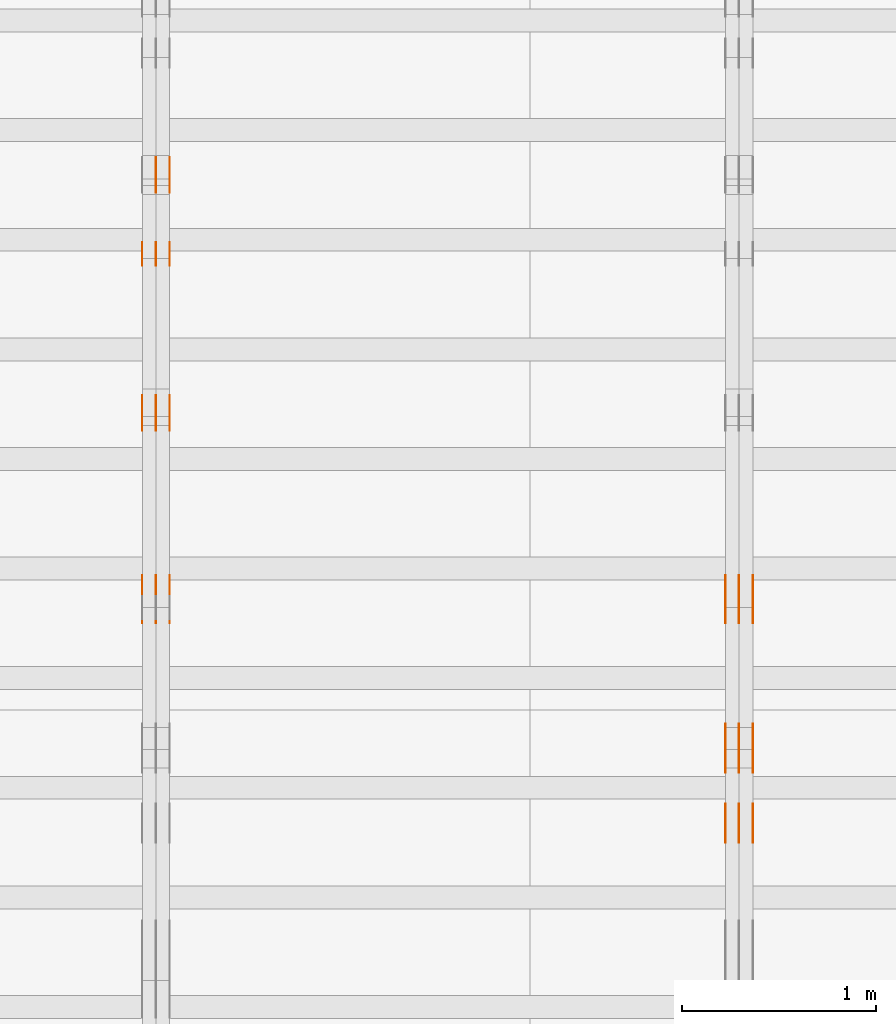
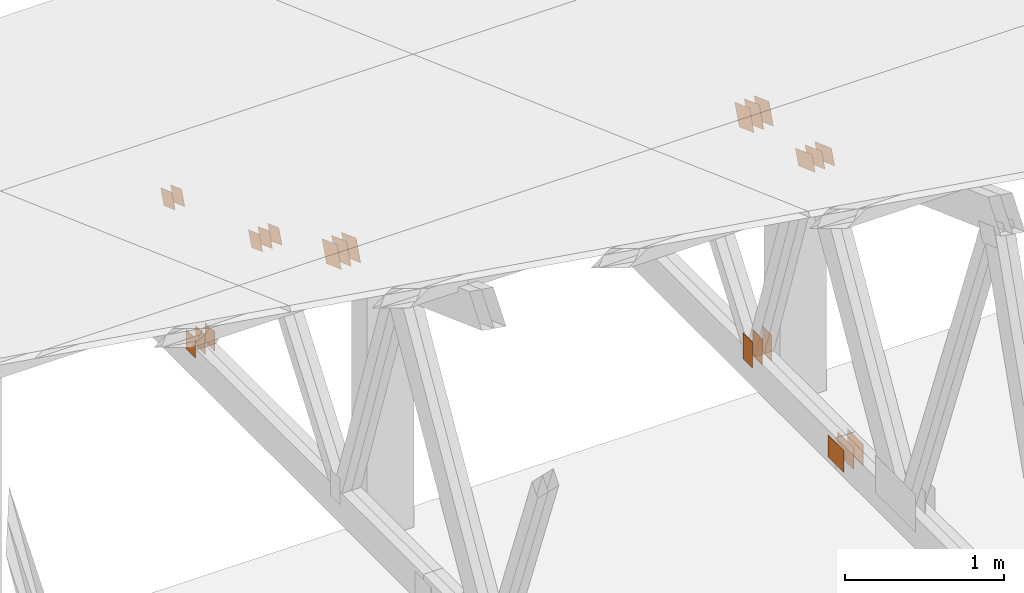
# One storey, part 132 of 189: 31 proxies.
"""IFC2X3 building model written with IfcOpenShell, lengths in millimetres."""

import ifcopenshell
import ifcopenshell.guid

model = None  # the IFC model being written
_history = None  # IfcOwnerHistory: only IFC2X3 demands one
_inside = {}  # id of a spatial element -> (the spatial element, [elements in it])
_under = {}  # id of a project, library or spatial element -> (it, [spatial elements below it])
_declared = {}  # id of a project -> (the project, [libraries it declares])
_typed = {}  # id of a type object -> (the type object, [elements of that type])
_made_of = {}  # id of a material, layer set ... -> (it, [elements and type objects made of it])


def new_model(schema):
    """Start an empty IFC model of exactly this schema.

    Asked for "IFC4X3", IfcOpenShell would pick the latest addendum, in which some entities
    have other attributes; the version numbers below select the first issue.
    IFC2X3 requires an IfcOwnerHistory on every rooted entity: one is made here for all.
    """
    global model, _history
    if schema == "IFC4X3":
        model = ifcopenshell.file(schema_version=(4, 3, 0, 0))
    else:
        model = ifcopenshell.file(schema=schema)
    _inside.clear()
    _under.clear()
    _declared.clear()
    _typed.clear()
    _made_of.clear()
    _history = None
    if model.schema == "IFC2X3":
        org = make("IfcOrganization", Name="unknown")
        user = make(
            "IfcPersonAndOrganization",
            ThePerson=make("IfcPerson", FamilyName="unknown"),
            TheOrganization=org,
        )
        app = make(
            "IfcApplication",
            ApplicationDeveloper=org,
            Version="unknown",
            ApplicationFullName="unknown",
            ApplicationIdentifier="unknown",
        )
        _history = make(
            "IfcOwnerHistory",
            OwningUser=user,
            OwningApplication=app,
            ChangeAction="ADDED",
            CreationDate=0,
        )
    return model


def make(cls, **values):
    """One entity of the class cls with the attributes given. An attribute that is None is left unset."""
    return model.create_entity(
        cls, **{name: value for name, value in values.items() if value is not None}
    )


def entity(cls, *values):
    """Any entity or typed value of the class cls, its attributes in the order of the schema. None: left unset."""
    e = model.create_entity(cls)
    for i, value in enumerate(values):
        if value is not None:
            e[i] = value
    return e


def rooted(cls, **values):
    """An entity with a GlobalId (a new one), such as an element, a storey or a relation."""
    return make(cls, GlobalId=ifcopenshell.guid.new(), OwnerHistory=_history, **values)


def si_unit(unit_type, name, prefix=None):
    """IfcSIUnit, for example si_unit("LENGTHUNIT", "METRE", prefix="MILLI")."""
    return make("IfcSIUnit", UnitType=unit_type, Prefix=prefix, Name=name)


def converted_unit(unit_type, name, factor, base, dimensions=None, offset=None):
    """IfcConversionBasedUnit, such as the inch: factor (a typed value) times the base unit."""
    return make(
        "IfcConversionBasedUnit"
        if offset is None
        else "IfcConversionBasedUnitWithOffset",
        ConversionOffset=offset,
        Dimensions=None
        if dimensions is None
        else entity("IfcDimensionalExponents", *dimensions),
        UnitType=unit_type,
        Name=name,
        ConversionFactor=make(
            "IfcMeasureWithUnit", ValueComponent=factor, UnitComponent=base
        ),
    )


def derived_unit(unit_type, elements):
    """IfcDerivedUnit: a product of units, each with its exponent."""
    return make(
        "IfcDerivedUnit",
        Elements=[
            make("IfcDerivedUnitElement", Unit=unit, Exponent=power)
            for unit, power in elements
        ],
        UnitType=unit_type,
    )


def assignment(units):
    """IfcUnitAssignment: the units of a project."""
    return None if units is None else make("IfcUnitAssignment", Units=units)


def point(xyz):
    """IfcCartesianPoint."""
    return None if xyz is None else make("IfcCartesianPoint", Coordinates=xyz)


def direction(xyz):
    """IfcDirection."""
    return None if xyz is None else make("IfcDirection", DirectionRatios=xyz)


def frame(location, z_axis=None, x_axis=None):
    """IfcAxis2Placement3D, a coordinate frame: its origin and axes. An axis left out is left unset."""
    return make(
        "IfcAxis2Placement3D",
        Location=point(location),
        Axis=direction(z_axis),
        RefDirection=direction(x_axis),
    )


def frame_2d(location, x_axis=None):
    """IfcAxis2Placement2D, a coordinate frame in the plane: its origin and x axis."""
    return make(
        "IfcAxis2Placement2D", Location=point(location), RefDirection=direction(x_axis)
    )


def origin():
    """The frame at (0, 0, 0) with its axes left unset."""
    return frame((0.0, 0.0, 0.0))


def origin_2d_with_axis():
    """The frame at (0, 0) in the plane with the x axis (1, 0) written out."""
    return frame_2d((0.0, 0.0), x_axis=(1.0, 0.0))


def place(relative_to, where):
    """IfcLocalPlacement: puts the frame where relative to a parent placement (None: the world)."""
    return make(
        "IfcLocalPlacement", PlacementRelTo=relative_to, RelativePlacement=where
    )


def context(
    kind, dimensions, precision=None, world=None, true_north=None, identifier=None
):
    """IfcGeometricRepresentationContext, for example the 3D "Model" context."""
    return make(
        "IfcGeometricRepresentationContext",
        ContextIdentifier=identifier,
        ContextType=kind,
        CoordinateSpaceDimension=dimensions,
        Precision=precision,
        WorldCoordinateSystem=world,
        TrueNorth=true_north,
    )


def subcontext(parent, identifier, kind, view, scale=None):
    """IfcGeometricRepresentationSubContext, for example "Body" below "Model"."""
    return make(
        "IfcGeometricRepresentationSubContext",
        ContextIdentifier=identifier,
        ContextType=kind,
        ParentContext=parent,
        TargetScale=scale,
        TargetView=view,
    )


def project(units=None, contexts=None):
    """IfcProject with its units and contexts."""
    return rooted(
        "IfcProject",
        Name="project",
        RepresentationContexts=contexts,
        UnitsInContext=assignment(units),
    )


def spatial(cls, under=None, at=None, **own):
    """A site, building, storey or space (cls), placed at a placement, below another one or the project."""
    s = rooted(cls, ObjectPlacement=at, **own)
    if under is not None:
        _under.setdefault(under.id(), (under, []))[1].append(s)
    return s


def polyline(points):
    """IfcPolyline through the points."""
    return make("IfcPolyline", Points=[point(p) for p in points])


def profile(cls, at=None, kind="AREA", **sizes):
    """A parametric profile (cls). Its sizes go by their IFC names, for example OverallWidth=200.0."""
    return make(cls, ProfileType=kind, Position=at, **sizes)


def rectangle(**sizes):
    """IfcRectangleProfileDef."""
    return profile("IfcRectangleProfileDef", **sizes)


def outline(outer, holes=None, kind="AREA"):
    """IfcArbitraryClosedProfileDef: a profile drawn as a closed curve; with holes, ...WithVoids."""
    if holes is None:
        return make("IfcArbitraryClosedProfileDef", ProfileType=kind, OuterCurve=outer)
    return make(
        "IfcArbitraryProfileDefWithVoids",
        ProfileType=kind,
        OuterCurve=outer,
        InnerCurves=holes,
    )


def extrude(swept, where, along, depth):
    """IfcExtrudedAreaSolid: the profile swept, set in the frame where, extruded along a direction by depth."""
    return make(
        "IfcExtrudedAreaSolid",
        SweptArea=swept,
        Position=where,
        ExtrudedDirection=direction(along),
        Depth=depth,
    )


def shape(context_of_items, identifier, shape_type, items):
    """IfcShapeRepresentation: the items that make up one representation, for example the "Body"."""
    return make(
        "IfcShapeRepresentation",
        ContextOfItems=context_of_items,
        RepresentationIdentifier=identifier,
        RepresentationType=shape_type,
        Items=items,
    )


def source(mapping_origin, context_of_items, identifier, shape_type, items):
    """IfcRepresentationMap: a shape defined once, which mapped items show again and again."""
    return make(
        "IfcRepresentationMap",
        MappingOrigin=mapping_origin,
        MappedRepresentation=shape(context_of_items, identifier, shape_type, items),
    )


def transform(
    local_origin,
    x_axis=None,
    y_axis=None,
    z_axis=None,
    scale=None,
    scale2=None,
    scale3=None,
    uniform=True,
):
    """IfcCartesianTransformationOperator3D, or its non-uniform kind. x_axis, y_axis, z_axis: its Axis1, 2, 3."""
    if uniform:
        return make(
            "IfcCartesianTransformationOperator3D",
            Axis1=direction(x_axis),
            Axis2=direction(y_axis),
            LocalOrigin=point(local_origin),
            Scale=scale,
            Axis3=direction(z_axis),
        )
    return make(
        "IfcCartesianTransformationOperator3DnonUniform",
        Axis1=direction(x_axis),
        Axis2=direction(y_axis),
        LocalOrigin=point(local_origin),
        Scale=scale,
        Axis3=direction(z_axis),
        Scale2=scale2,
        Scale3=scale3,
    )


def mapped(mapping_source, mapping_target):
    """IfcMappedItem: shows the shape of a source again, moved by a transform."""
    return make(
        "IfcMappedItem", MappingSource=mapping_source, MappingTarget=mapping_target
    )


def material(Name=None, Category=None):
    """IfcMaterial."""
    return make("IfcMaterial", Name=Name, Category=Category)


def made_of(thing, what):
    """Note that an element or type object is made of a material, layer set ...; save() writes the relation."""
    if what is not None:
        _made_of.setdefault(what.id(), (what, []))[1].append(thing)
    return thing


def type_object(cls, material=None, **own):
    """A type object (cls), such as IfcWallType, which elements share."""
    return made_of(rooted(cls, **own), material)


def type_shapes(of_type, sources):
    """Give a type object the sources (RepresentationMaps) that its elements show as mapped items."""
    of_type.RepresentationMaps = sources


def element(
    cls,
    number,
    at=None,
    inside=None,
    cuts=None,
    type_object=None,
    material=None,
    context=None,
    identifier="Body",
    shape_type=None,
    held_by="IfcProductDefinitionShape",
    body=None,
    shapes=None,
    **own,
):
    """One element of the class cls, such as IfcWall. Its Tag is "e" and its number.

    at: its placement. inside: the storey or other place that contains it. cuts: it is an
    opening in that element (IfcRelVoidsElement). A single representation is given by context,
    identifier, shape_type and body (its items); several are given by shapes. held_by: the class
    of the entity that holds the representations. save() writes the other relations.
    """
    e = rooted(cls, Tag="e%d" % number, ObjectPlacement=at, **own)
    if body is not None:
        shapes = [shape(context, identifier, shape_type, body)]
    if shapes is not None:
        e.Representation = make(held_by, Representations=shapes)
    if inside is not None:
        _inside.setdefault(inside.id(), (inside, []))[1].append(e)
    if cuts is not None:
        rooted(
            "IfcRelVoidsElement", RelatingBuildingElement=cuts, RelatedOpeningElement=e
        )
    if type_object is not None:
        _typed.setdefault(type_object.id(), (type_object, []))[1].append(e)
    return made_of(e, material)


def aggregate(whole, parts):
    """IfcRelAggregates: a whole, such as a stair, and the parts it consists of."""
    return rooted("IfcRelAggregates", RelatingObject=whole, RelatedObjects=parts)


def save(model, path):
    """Write the relations noted so far, then the file.

    IfcRelAggregates (storeys below a building ...), IfcRelContainedInSpatialStructure (elements
    in a storey), IfcRelDefinesByType, IfcRelAssociatesMaterial and IfcRelDeclares: one each for
    every whole, place, type object, material and project.
    """
    for whole, parts in _under.values():
        aggregate(whole, parts)
    for where, things in _inside.values():
        rooted(
            "IfcRelContainedInSpatialStructure",
            RelatedElements=things,
            RelatingStructure=where,
        )
    for kind, things in _typed.values():
        rooted("IfcRelDefinesByType", RelatedObjects=things, RelatingType=kind)
    for what, things in _made_of.values():
        rooted("IfcRelAssociatesMaterial", RelatedObjects=things, RelatingMaterial=what)
    for by, libraries in _declared.values():
        rooted("IfcRelDeclares", RelatingContext=by, RelatedDefinitions=libraries)
    model.write(path)


model = new_model("IFC2X3")

# Units and contexts
model_context = context("Model", 3, precision=0.01, world=origin(), true_north=direction((6.12303176911189e-17, 1.0)))
body_context = subcontext(model_context, "Body", "Model", "MODEL_VIEW")
ifc_project = project(units=[si_unit("LENGTHUNIT", "METRE", prefix="MILLI"), si_unit("AREAUNIT", "SQUARE_METRE"), si_unit("VOLUMEUNIT", "CUBIC_METRE"), converted_unit("PLANEANGLEUNIT", "DEGREE", entity("IfcRatioMeasure", 0.0174532925199433), si_unit("PLANEANGLEUNIT", "RADIAN"), dimensions=[0, 0, 0, 0, 0, 0, 0]), si_unit("MASSUNIT", "GRAM", prefix="KILO"), derived_unit("MASSDENSITYUNIT", [(si_unit("MASSUNIT", "GRAM", prefix="KILO"), 1), (si_unit("LENGTHUNIT", "METRE"), -3)]), si_unit("TIMEUNIT", "SECOND"), si_unit("FREQUENCYUNIT", "HERTZ"), si_unit("THERMODYNAMICTEMPERATUREUNIT", "DEGREE_CELSIUS"), derived_unit("THERMALTRANSMITTANCEUNIT", [(si_unit("MASSUNIT", "GRAM", prefix="KILO"), 1), (si_unit("THERMODYNAMICTEMPERATUREUNIT", "KELVIN"), -1), (si_unit("TIMEUNIT", "SECOND"), -3)]), derived_unit("VOLUMETRICFLOWRATEUNIT", [(si_unit("LENGTHUNIT", "METRE"), 3), (si_unit("TIMEUNIT", "SECOND"), -1)]), si_unit("ELECTRICCURRENTUNIT", "AMPERE"), si_unit("ELECTRICVOLTAGEUNIT", "VOLT"), si_unit("POWERUNIT", "WATT"), si_unit("FORCEUNIT", "NEWTON"), si_unit("ILLUMINANCEUNIT", "LUX"), si_unit("LUMINOUSFLUXUNIT", "LUMEN"), si_unit("LUMINOUSINTENSITYUNIT", "CANDELA"), derived_unit("USERDEFINED", [(si_unit("MASSUNIT", "GRAM", prefix="KILO"), -1), (si_unit("LENGTHUNIT", "METRE"), -2), (si_unit("TIMEUNIT", "SECOND"), 3), (si_unit("LUMINOUSFLUXUNIT", "LUMEN"), 1)]), derived_unit("LINEARVELOCITYUNIT", [(si_unit("LENGTHUNIT", "METRE"), 1), (si_unit("TIMEUNIT", "SECOND"), -1)]), si_unit("PRESSUREUNIT", "PASCAL"), derived_unit("USERDEFINED", [(si_unit("LENGTHUNIT", "METRE"), -2), (si_unit("MASSUNIT", "GRAM", prefix="KILO"), 1), (si_unit("TIMEUNIT", "SECOND"), -2)])], contexts=[model_context])

# Site, building, storey
site_placement = place(None, origin())
site = spatial("IfcSite", under=ifc_project, at=site_placement, CompositionType="ELEMENT")
building_placement = place(site_placement, origin())
building = spatial("IfcBuilding", under=site, at=building_placement, CompositionType="ELEMENT")
storey_placement = place(building_placement, origin())
storey = spatial("IfcBuildingStorey", under=building, at=storey_placement, Name="Default", CompositionType="ELEMENT", Elevation=0.0)

# Proxies
ifc_material_1 = material(Name="IfcSurfaceStyle #169638")
building_element_proxy_type_1 = type_object("IfcBuildingElementProxyType", PredefinedType="NOTDEFINED", material=ifc_material_1)
shared_shape_1 = source(origin(), body_context, "Body", "SweptSolid", [
    extrude(outline(polyline([(-112.499846801582, -59.999986193028), (112.499924372729, -59.999986193028), (112.499888552087, 59.999986193028), (-112.499966123235, 59.999986193028), (-112.499846801582, -59.999986193028)])), frame((112.499989807712, 60.0001003787081, 0.0), z_axis=(0.0, 0.0, 1.0), x_axis=(-1.0, 0.0, 0.0)), (0.0, 0.0, 1.0), 1.3),
])
type_shapes(building_element_proxy_type_1, [shared_shape_1])
proxy_1_placement = place(building_placement, frame((30301.3, 24040.8868138992, 2049.61031693104), z_axis=(-1.0, 0.0, 0.0), x_axis=(0.0, -0.939692620785908, 0.342020143325669)))
element("IfcBuildingElementProxy", 1, at=proxy_1_placement, inside=storey, type_object=building_element_proxy_type_1, material=ifc_material_1, context=body_context, shape_type="MappedRepresentation", body=[
    mapped(shared_shape_1, transform((0.0, 0.0, 0.0), scale=1.0)),
])
ifc_material_2 = material(Name="IfcSurfaceStyle #169581")
building_element_proxy_type_2 = type_object("IfcBuildingElementProxyType", PredefinedType="NOTDEFINED", material=ifc_material_2)
shared_shape_2 = source(origin(), body_context, "Body", "SweptSolid", [
    extrude(outline(polyline([(-112.499846801582, -59.999986193028), (112.499924372729, -59.999986193028), (112.499888552087, 59.999986193028), (-112.499966123235, 59.999986193028), (-112.499846801582, -59.999986193028)])), frame((112.499989807712, 60.0001003787081, 0.0), z_axis=(0.0, 0.0, 1.0), x_axis=(-1.0, 0.0, 0.0)), (0.0, 0.0, 1.0), 1.29999999999998),
])
type_shapes(building_element_proxy_type_2, [shared_shape_2])
proxy_2_placement = place(building_placement, frame((30230.0, 24040.8868138992, 2049.61031693104), z_axis=(-1.0, 0.0, 0.0), x_axis=(0.0, -0.939692620785908, 0.342020143325669)))
element("IfcBuildingElementProxy", 2, at=proxy_2_placement, inside=storey, type_object=building_element_proxy_type_2, material=ifc_material_2, context=body_context, shape_type="MappedRepresentation", body=[
    mapped(shared_shape_2, transform((0.0, 0.0, 0.0), scale=1.0)),
])
ifc_material_3 = material(Name="IfcSurfaceStyle #169524")
building_element_proxy_type_3 = type_object("IfcBuildingElementProxyType", PredefinedType="NOTDEFINED", material=ifc_material_3)
shared_shape_3 = source(origin(), body_context, "Body", "SweptSolid", [
    extrude(outline(polyline([(-112.499846801582, -59.999986193028), (112.499924372729, -59.999986193028), (112.499888552087, 59.999986193028), (-112.499966123235, 59.999986193028), (-112.499846801582, -59.999986193028)])), frame((112.499989807712, 60.0001003787081, 0.0), z_axis=(0.0, 0.0, 1.0), x_axis=(-1.0, 0.0, 0.0)), (0.0, 0.0, 1.0), 1.29999999999998),
])
type_shapes(building_element_proxy_type_3, [shared_shape_3])
proxy_3_placement = place(building_placement, frame((30231.3, 24040.8868138992, 2049.61031693104), z_axis=(-1.0, 0.0, 0.0), x_axis=(0.0, -0.939692620785908, 0.342020143325669)))
element("IfcBuildingElementProxy", 3, at=proxy_3_placement, inside=storey, type_object=building_element_proxy_type_3, material=ifc_material_3, context=body_context, shape_type="MappedRepresentation", body=[
    mapped(shared_shape_3, transform((0.0, 0.0, 0.0), scale=1.0)),
])
ifc_material_4 = material(Name="IfcSurfaceStyle #169467")
building_element_proxy_type_4 = type_object("IfcBuildingElementProxyType", PredefinedType="NOTDEFINED", material=ifc_material_4)
shared_shape_4 = source(origin(), body_context, "Body", "SweptSolid", [
    extrude(outline(polyline([(-112.499846801582, -59.999986193028), (112.499924372729, -59.999986193028), (112.499888552087, 59.999986193028), (-112.499966123235, 59.999986193028), (-112.499846801582, -59.999986193028)])), frame((112.499989807712, 60.0001003787081, 0.0), z_axis=(0.0, 0.0, 1.0), x_axis=(-1.0, 0.0, 0.0)), (0.0, 0.0, 1.0), 1.29999999999999),
])
type_shapes(building_element_proxy_type_4, [shared_shape_4])
proxy_4_placement = place(building_placement, frame((30160.0, 24040.8868138992, 2049.61031693104), z_axis=(-1.0, 0.0, 0.0), x_axis=(0.0, -0.939692620785908, 0.342020143325669)))
element("IfcBuildingElementProxy", 4, at=proxy_4_placement, inside=storey, type_object=building_element_proxy_type_4, material=ifc_material_4, context=body_context, shape_type="MappedRepresentation", body=[
    mapped(shared_shape_4, transform((0.0, 0.0, 0.0), scale=1.0)),
])
ifc_material_5 = material(Name="IfcSurfaceStyle #169410")
building_element_proxy_type_5 = type_object("IfcBuildingElementProxyType", PredefinedType="NOTDEFINED", material=ifc_material_5)
shared_shape_5 = source(origin(), body_context, "Body", "SweptSolid", [
    extrude(rectangle(XDim=200.0, YDim=120.0, at=origin_2d_with_axis()), frame((100.0, 60.0002296775929, 0.0), z_axis=(0.0, 0.0, 1.0), x_axis=(-1.0, 0.0, 0.0)), (0.0, 0.0, 1.0), 1.3),
])
type_shapes(building_element_proxy_type_5, [shared_shape_5])
proxy_5_placement = place(building_placement, frame((30301.3, 24619.3435203224, 145.0), z_axis=(-1.0, 0.0, 0.0), x_axis=(0.0, 0.0, 1.0)))
element("IfcBuildingElementProxy", 5, at=proxy_5_placement, inside=storey, type_object=building_element_proxy_type_5, material=ifc_material_5, context=body_context, shape_type="MappedRepresentation", body=[
    mapped(shared_shape_5, transform((0.0, 0.0, 0.0), scale=1.0)),
])
ifc_material_6 = material(Name="IfcSurfaceStyle #169353")
building_element_proxy_type_6 = type_object("IfcBuildingElementProxyType", PredefinedType="NOTDEFINED", material=ifc_material_6)
shared_shape_6 = source(origin(), body_context, "Body", "SweptSolid", [
    extrude(rectangle(XDim=200.0, YDim=120.0, at=origin_2d_with_axis()), frame((100.0, 60.0002296775929, 0.0), z_axis=(0.0, 0.0, 1.0), x_axis=(-1.0, 0.0, 0.0)), (0.0, 0.0, 1.0), 1.29999999999998),
])
type_shapes(building_element_proxy_type_6, [shared_shape_6])
proxy_6_placement = place(building_placement, frame((30230.0, 24619.3435203224, 145.0), z_axis=(-1.0, 0.0, 0.0), x_axis=(0.0, 0.0, 1.0)))
element("IfcBuildingElementProxy", 6, at=proxy_6_placement, inside=storey, type_object=building_element_proxy_type_6, material=ifc_material_6, context=body_context, shape_type="MappedRepresentation", body=[
    mapped(shared_shape_6, transform((0.0, 0.0, 0.0), scale=1.0)),
])
ifc_material_7 = material(Name="IfcSurfaceStyle #169296")
building_element_proxy_type_7 = type_object("IfcBuildingElementProxyType", PredefinedType="NOTDEFINED", material=ifc_material_7)
shared_shape_7 = source(origin(), body_context, "Body", "SweptSolid", [
    extrude(rectangle(XDim=200.0, YDim=120.0, at=origin_2d_with_axis()), frame((100.0, 60.0002296775929, 0.0), z_axis=(0.0, 0.0, 1.0), x_axis=(-1.0, 0.0, 0.0)), (0.0, 0.0, 1.0), 1.29999999999998),
])
type_shapes(building_element_proxy_type_7, [shared_shape_7])
proxy_7_placement = place(building_placement, frame((30231.3, 24619.3435203224, 145.0), z_axis=(-1.0, 0.0, 0.0), x_axis=(0.0, 0.0, 1.0)))
element("IfcBuildingElementProxy", 7, at=proxy_7_placement, inside=storey, type_object=building_element_proxy_type_7, material=ifc_material_7, context=body_context, shape_type="MappedRepresentation", body=[
    mapped(shared_shape_7, transform((0.0, 0.0, 0.0), scale=1.0)),
])
ifc_material_8 = material(Name="IfcSurfaceStyle #169239")
building_element_proxy_type_8 = type_object("IfcBuildingElementProxyType", PredefinedType="NOTDEFINED", material=ifc_material_8)
shared_shape_8 = source(origin(), body_context, "Body", "SweptSolid", [
    extrude(rectangle(XDim=200.0, YDim=120.0, at=origin_2d_with_axis()), frame((100.0, 60.0002296775929, 0.0), z_axis=(0.0, 0.0, 1.0), x_axis=(-1.0, 0.0, 0.0)), (0.0, 0.0, 1.0), 1.29999999999999),
])
type_shapes(building_element_proxy_type_8, [shared_shape_8])
proxy_8_placement = place(building_placement, frame((30160.0, 24619.3435203224, 145.0), z_axis=(-1.0, 0.0, 0.0), x_axis=(0.0, 0.0, 1.0)))
element("IfcBuildingElementProxy", 8, at=proxy_8_placement, inside=storey, type_object=building_element_proxy_type_8, material=ifc_material_8, context=body_context, shape_type="MappedRepresentation", body=[
    mapped(shared_shape_8, transform((0.0, 0.0, 0.0), scale=1.0)),
])
ifc_material_9 = material(Name="IfcSurfaceStyle #165762")
building_element_proxy_type_9 = type_object("IfcBuildingElementProxyType", PredefinedType="NOTDEFINED", material=ifc_material_9)
shared_shape_9 = source(origin(), body_context, "Body", "SweptSolid", [
    extrude(rectangle(XDim=200.0, YDim=168.0, at=origin_2d_with_axis()), frame((100.0, 84.0, 0.0), z_axis=(0.0, 0.0, 1.0), x_axis=(-1.0, 0.0, 0.0)), (0.0, 0.0, 1.0), 1.3),
])
type_shapes(building_element_proxy_type_9, [shared_shape_9])
proxy_9_placement = place(building_placement, frame((30301.3, 23470.0, 206.5), z_axis=(-1.0, 0.0, 0.0), x_axis=(0.0, 1.0, 0.0)))
element("IfcBuildingElementProxy", 9, at=proxy_9_placement, inside=storey, type_object=building_element_proxy_type_9, material=ifc_material_9, context=body_context, shape_type="MappedRepresentation", body=[
    mapped(shared_shape_9, transform((0.0, 0.0, 0.0), scale=1.0)),
])
ifc_material_10 = material(Name="IfcSurfaceStyle #165705")
building_element_proxy_type_10 = type_object("IfcBuildingElementProxyType", PredefinedType="NOTDEFINED", material=ifc_material_10)
shared_shape_10 = source(origin(), body_context, "Body", "SweptSolid", [
    extrude(rectangle(XDim=200.0, YDim=168.0, at=origin_2d_with_axis()), frame((100.0, 84.0, 0.0), z_axis=(0.0, 0.0, 1.0), x_axis=(-1.0, 0.0, 0.0)), (0.0, 0.0, 1.0), 1.29999999999998),
])
type_shapes(building_element_proxy_type_10, [shared_shape_10])
proxy_10_placement = place(building_placement, frame((30230.0, 23470.0, 206.5), z_axis=(-1.0, 0.0, 0.0), x_axis=(0.0, 1.0, 0.0)))
element("IfcBuildingElementProxy", 10, at=proxy_10_placement, inside=storey, type_object=building_element_proxy_type_10, material=ifc_material_10, context=body_context, shape_type="MappedRepresentation", body=[
    mapped(shared_shape_10, transform((0.0, 0.0, 0.0), scale=1.0)),
])
ifc_material_11 = material(Name="IfcSurfaceStyle #165648")
building_element_proxy_type_11 = type_object("IfcBuildingElementProxyType", PredefinedType="NOTDEFINED", material=ifc_material_11)
shared_shape_11 = source(origin(), body_context, "Body", "SweptSolid", [
    extrude(rectangle(XDim=200.0, YDim=168.0, at=origin_2d_with_axis()), frame((100.0, 84.0, 0.0), z_axis=(0.0, 0.0, 1.0), x_axis=(-1.0, 0.0, 0.0)), (0.0, 0.0, 1.0), 1.29999999999998),
])
type_shapes(building_element_proxy_type_11, [shared_shape_11])
proxy_11_placement = place(building_placement, frame((30231.3, 23470.0, 206.5), z_axis=(-1.0, 0.0, 0.0), x_axis=(0.0, 1.0, 0.0)))
element("IfcBuildingElementProxy", 11, at=proxy_11_placement, inside=storey, type_object=building_element_proxy_type_11, material=ifc_material_11, context=body_context, shape_type="MappedRepresentation", body=[
    mapped(shared_shape_11, transform((0.0, 0.0, 0.0), scale=1.0)),
])
ifc_material_12 = material(Name="IfcSurfaceStyle #165591")
building_element_proxy_type_12 = type_object("IfcBuildingElementProxyType", PredefinedType="NOTDEFINED", material=ifc_material_12)
shared_shape_12 = source(origin(), body_context, "Body", "SweptSolid", [
    extrude(rectangle(XDim=200.0, YDim=168.0, at=origin_2d_with_axis()), frame((100.0, 84.0, 0.0), z_axis=(0.0, 0.0, 1.0), x_axis=(-1.0, 0.0, 0.0)), (0.0, 0.0, 1.0), 1.29999999999999),
])
type_shapes(building_element_proxy_type_12, [shared_shape_12])
proxy_12_placement = place(building_placement, frame((30160.0, 23470.0, 206.5), z_axis=(-1.0, 0.0, 0.0), x_axis=(0.0, 1.0, 0.0)))
element("IfcBuildingElementProxy", 12, at=proxy_12_placement, inside=storey, type_object=building_element_proxy_type_12, material=ifc_material_12, context=body_context, shape_type="MappedRepresentation", body=[
    mapped(shared_shape_12, transform((0.0, 0.0, 0.0), scale=1.0)),
])
ifc_material_13 = material(Name="IfcSurfaceStyle #163602")
building_element_proxy_type_13 = type_object("IfcBuildingElementProxyType", PredefinedType="NOTDEFINED", material=ifc_material_13)
shared_shape_13 = source(origin(), body_context, "Body", "SweptSolid", [
    extrude(outline(polyline([(-99.9999065788418, -84.0000755647729), (99.9999734279406, -84.0000755647729), (99.9999483293475, 84.000075564773), (-100.000015178446, 84.000075564773), (-99.9999065788418, -84.0000755647729)])), frame((100.000157783747, 84.0001144608011, 0.0), z_axis=(0.0, 0.0, 1.0), x_axis=(-1.0, 0.0, 0.0)), (0.0, 0.0, 1.0), 1.3),
])
type_shapes(building_element_proxy_type_13, [shared_shape_13])
proxy_13_placement = place(building_placement, frame((30301.3, 24788.4767593228, 1895.10136879206), z_axis=(-1.0, 0.0, 0.0), x_axis=(0.0, -0.939692620785908, 0.342020143325669)))
element("IfcBuildingElementProxy", 13, at=proxy_13_placement, inside=storey, type_object=building_element_proxy_type_13, material=ifc_material_13, context=body_context, shape_type="MappedRepresentation", body=[
    mapped(shared_shape_13, transform((0.0, 0.0, 0.0), scale=1.0)),
])
ifc_material_14 = material(Name="IfcSurfaceStyle #163545")
building_element_proxy_type_14 = type_object("IfcBuildingElementProxyType", PredefinedType="NOTDEFINED", material=ifc_material_14)
shared_shape_14 = source(origin(), body_context, "Body", "SweptSolid", [
    extrude(outline(polyline([(-99.9999065788418, -84.0000755647729), (99.9999734279406, -84.0000755647729), (99.9999483293475, 84.000075564773), (-100.000015178446, 84.000075564773), (-99.9999065788418, -84.0000755647729)])), frame((100.000157783747, 84.0001144608011, 0.0), z_axis=(0.0, 0.0, 1.0), x_axis=(-1.0, 0.0, 0.0)), (0.0, 0.0, 1.0), 1.29999999999998),
])
type_shapes(building_element_proxy_type_14, [shared_shape_14])
proxy_14_placement = place(building_placement, frame((30230.0, 24788.4767593228, 1895.10136879206), z_axis=(-1.0, 0.0, 0.0), x_axis=(0.0, -0.939692620785908, 0.342020143325669)))
element("IfcBuildingElementProxy", 14, at=proxy_14_placement, inside=storey, type_object=building_element_proxy_type_14, material=ifc_material_14, context=body_context, shape_type="MappedRepresentation", body=[
    mapped(shared_shape_14, transform((0.0, 0.0, 0.0), scale=1.0)),
])
ifc_material_15 = material(Name="IfcSurfaceStyle #163488")
building_element_proxy_type_15 = type_object("IfcBuildingElementProxyType", PredefinedType="NOTDEFINED", material=ifc_material_15)
shared_shape_15 = source(origin(), body_context, "Body", "SweptSolid", [
    extrude(outline(polyline([(-99.9999065788418, -84.0000755647729), (99.9999734279406, -84.0000755647729), (99.9999483293475, 84.000075564773), (-100.000015178446, 84.000075564773), (-99.9999065788418, -84.0000755647729)])), frame((100.000157783747, 84.0001144608011, 0.0), z_axis=(0.0, 0.0, 1.0), x_axis=(-1.0, 0.0, 0.0)), (0.0, 0.0, 1.0), 1.29999999999998),
])
type_shapes(building_element_proxy_type_15, [shared_shape_15])
proxy_15_placement = place(building_placement, frame((30231.3, 24788.4767593228, 1895.10136879206), z_axis=(-1.0, 0.0, 0.0), x_axis=(0.0, -0.939692620785908, 0.342020143325669)))
element("IfcBuildingElementProxy", 15, at=proxy_15_placement, inside=storey, type_object=building_element_proxy_type_15, material=ifc_material_15, context=body_context, shape_type="MappedRepresentation", body=[
    mapped(shared_shape_15, transform((0.0, 0.0, 0.0), scale=1.0)),
])
ifc_material_16 = material(Name="IfcSurfaceStyle #163431")
building_element_proxy_type_16 = type_object("IfcBuildingElementProxyType", PredefinedType="NOTDEFINED", material=ifc_material_16)
shared_shape_16 = source(origin(), body_context, "Body", "SweptSolid", [
    extrude(outline(polyline([(-99.9999065788418, -84.0000755647729), (99.9999734279406, -84.0000755647729), (99.9999483293475, 84.000075564773), (-100.000015178446, 84.000075564773), (-99.9999065788418, -84.0000755647729)])), frame((100.000157783747, 84.0001144608011, 0.0), z_axis=(0.0, 0.0, 1.0), x_axis=(-1.0, 0.0, 0.0)), (0.0, 0.0, 1.0), 1.29999999999999),
])
type_shapes(building_element_proxy_type_16, [shared_shape_16])
proxy_16_placement = place(building_placement, frame((30160.0, 24788.4767593228, 1895.10136879206), z_axis=(-1.0, 0.0, 0.0), x_axis=(0.0, -0.939692620785908, 0.342020143325669)))
element("IfcBuildingElementProxy", 16, at=proxy_16_placement, inside=storey, type_object=building_element_proxy_type_16, material=ifc_material_16, context=body_context, shape_type="MappedRepresentation", body=[
    mapped(shared_shape_16, transform((0.0, 0.0, 0.0), scale=1.0)),
])
ifc_material_17 = material(Name="IfcSurfaceStyle #152936")
building_element_proxy_type_17 = type_object("IfcBuildingElementProxyType", PredefinedType="NOTDEFINED", material=ifc_material_17)
shared_shape_17 = source(origin(), body_context, "Body", "SweptSolid", [
    extrude(outline(polyline([(-74.9999475298494, -60.0), (75.0000042257432, -60.0), (74.9999684051025, 60.0), (-75.0000251009963, 60.0), (-74.9999475298494, -60.0)])), frame((75.0000607644577, 60.0000865490217, 0.0), z_axis=(0.0, 0.0, 1.0), x_axis=(-1.0, 0.0, 0.0)), (0.0, 0.0, 1.0), 1.3),
])
type_shapes(building_element_proxy_type_17, [shared_shape_17])
proxy_17_placement = place(building_placement, frame((27301.3, 25732.0586805394, 1446.84420669249), z_axis=(-1.0, 0.0, 0.0), x_axis=(0.0, -0.939692620785908, 0.342020143325669)))
element("IfcBuildingElementProxy", 17, at=proxy_17_placement, inside=storey, type_object=building_element_proxy_type_17, material=ifc_material_17, context=body_context, shape_type="MappedRepresentation", body=[
    mapped(shared_shape_17, transform((0.0, 0.0, 0.0), scale=1.0)),
])
ifc_material_18 = material(Name="IfcSurfaceStyle #152879")
building_element_proxy_type_18 = type_object("IfcBuildingElementProxyType", PredefinedType="NOTDEFINED", material=ifc_material_18)
shared_shape_18 = source(origin(), body_context, "Body", "SweptSolid", [
    extrude(outline(polyline([(-74.9999475298494, -60.0), (75.0000042257432, -60.0), (74.9999684051025, 60.0), (-75.0000251009963, 60.0), (-74.9999475298494, -60.0)])), frame((75.0000607644577, 60.0000865490217, 0.0), z_axis=(0.0, 0.0, 1.0), x_axis=(-1.0, 0.0, 0.0)), (0.0, 0.0, 1.0), 1.29999999999999),
])
type_shapes(building_element_proxy_type_18, [shared_shape_18])
proxy_18_placement = place(building_placement, frame((27230.0, 25732.0586805394, 1446.84420669249), z_axis=(-1.0, 0.0, 0.0), x_axis=(0.0, -0.939692620785908, 0.342020143325669)))
element("IfcBuildingElementProxy", 18, at=proxy_18_placement, inside=storey, type_object=building_element_proxy_type_18, material=ifc_material_18, context=body_context, shape_type="MappedRepresentation", body=[
    mapped(shared_shape_18, transform((0.0, 0.0, 0.0), scale=1.0)),
])
ifc_material_19 = material(Name="IfcSurfaceStyle #152822")
building_element_proxy_type_19 = type_object("IfcBuildingElementProxyType", PredefinedType="NOTDEFINED", material=ifc_material_19)
shared_shape_19 = source(origin(), body_context, "Body", "SweptSolid", [
    extrude(outline(polyline([(-74.9999475298494, -60.0), (75.0000042257432, -60.0), (74.9999684051025, 60.0), (-75.0000251009963, 60.0), (-74.9999475298494, -60.0)])), frame((75.0000607644577, 60.0000865490217, 0.0), z_axis=(0.0, 0.0, 1.0), x_axis=(-1.0, 0.0, 0.0)), (0.0, 0.0, 1.0), 1.29999999999999),
])
type_shapes(building_element_proxy_type_19, [shared_shape_19])
proxy_19_placement = place(building_placement, frame((27231.3, 25732.0586805394, 1446.84420669249), z_axis=(-1.0, 0.0, 0.0), x_axis=(0.0, -0.939692620785908, 0.342020143325669)))
element("IfcBuildingElementProxy", 19, at=proxy_19_placement, inside=storey, type_object=building_element_proxy_type_19, material=ifc_material_19, context=body_context, shape_type="MappedRepresentation", body=[
    mapped(shared_shape_19, transform((0.0, 0.0, 0.0), scale=1.0)),
])
ifc_material_20 = material(Name="IfcSurfaceStyle #152765")
building_element_proxy_type_20 = type_object("IfcBuildingElementProxyType", PredefinedType="NOTDEFINED", material=ifc_material_20)
shared_shape_20 = source(origin(), body_context, "Body", "SweptSolid", [
    extrude(outline(polyline([(-74.9999475298494, -60.0), (75.0000042257432, -60.0), (74.9999684051025, 60.0), (-75.0000251009963, 60.0), (-74.9999475298494, -60.0)])), frame((75.0000607644577, 60.0000865490217, 0.0), z_axis=(0.0, 0.0, 1.0), x_axis=(-1.0, 0.0, 0.0)), (0.0, 0.0, 1.0), 1.29999999999999),
])
type_shapes(building_element_proxy_type_20, [shared_shape_20])
proxy_20_placement = place(building_placement, frame((27160.0, 25732.0586805394, 1446.84420669249), z_axis=(-1.0, 0.0, 0.0), x_axis=(0.0, -0.939692620785908, 0.342020143325669)))
element("IfcBuildingElementProxy", 20, at=proxy_20_placement, inside=storey, type_object=building_element_proxy_type_20, material=ifc_material_20, context=body_context, shape_type="MappedRepresentation", body=[
    mapped(shared_shape_20, transform((0.0, 0.0, 0.0), scale=1.0)),
])
ifc_material_21 = material(Name="IfcSurfaceStyle #152708")
building_element_proxy_type_21 = type_object("IfcBuildingElementProxyType", PredefinedType="NOTDEFINED", material=ifc_material_21)
shared_shape_21 = source(origin(), body_context, "Body", "SweptSolid", [
    extrude(rectangle(XDim=150.0, YDim=120.0, at=frame_2d((-7.105427357601e-15, 0.0), x_axis=(1.0, 0.0))), frame((75.0, 60.0, 0.0), z_axis=(0.0, 0.0, 1.0), x_axis=(-1.0, 0.0, 0.0)), (0.0, 0.0, 1.0), 1.3),
])
type_shapes(building_element_proxy_type_21, [shared_shape_21])
proxy_21_placement = place(building_placement, frame((27301.3, 26439.0083007813, 170.0), z_axis=(-1.0, 0.0, 0.0), x_axis=(0.0, 0.0, 1.0)))
element("IfcBuildingElementProxy", 21, at=proxy_21_placement, inside=storey, type_object=building_element_proxy_type_21, material=ifc_material_21, context=body_context, shape_type="MappedRepresentation", body=[
    mapped(shared_shape_21, transform((0.0, 0.0, 0.0), scale=1.0)),
])
ifc_material_22 = material(Name="IfcSurfaceStyle #152651")
building_element_proxy_type_22 = type_object("IfcBuildingElementProxyType", PredefinedType="NOTDEFINED", material=ifc_material_22)
shared_shape_22 = source(origin(), body_context, "Body", "SweptSolid", [
    extrude(rectangle(XDim=150.0, YDim=120.0, at=frame_2d((-7.105427357601e-15, 0.0), x_axis=(1.0, 0.0))), frame((75.0, 60.0, 0.0), z_axis=(0.0, 0.0, 1.0), x_axis=(-1.0, 0.0, 0.0)), (0.0, 0.0, 1.0), 1.29999999999999),
])
type_shapes(building_element_proxy_type_22, [shared_shape_22])
proxy_22_placement = place(building_placement, frame((27230.0, 26439.0083007813, 170.0), z_axis=(-1.0, 0.0, 0.0), x_axis=(0.0, 0.0, 1.0)))
element("IfcBuildingElementProxy", 22, at=proxy_22_placement, inside=storey, type_object=building_element_proxy_type_22, material=ifc_material_22, context=body_context, shape_type="MappedRepresentation", body=[
    mapped(shared_shape_22, transform((0.0, 0.0, 0.0), scale=1.0)),
])
ifc_material_23 = material(Name="IfcSurfaceStyle #152594")
building_element_proxy_type_23 = type_object("IfcBuildingElementProxyType", PredefinedType="NOTDEFINED", material=ifc_material_23)
shared_shape_23 = source(origin(), body_context, "Body", "SweptSolid", [
    extrude(rectangle(XDim=150.0, YDim=120.0, at=frame_2d((-7.105427357601e-15, 0.0), x_axis=(1.0, 0.0))), frame((75.0, 60.0, 0.0), z_axis=(0.0, 0.0, 1.0), x_axis=(-1.0, 0.0, 0.0)), (0.0, 0.0, 1.0), 1.29999999999999),
])
type_shapes(building_element_proxy_type_23, [shared_shape_23])
proxy_23_placement = place(building_placement, frame((27231.3, 26439.0083007813, 170.0), z_axis=(-1.0, 0.0, 0.0), x_axis=(0.0, 0.0, 1.0)))
element("IfcBuildingElementProxy", 23, at=proxy_23_placement, inside=storey, type_object=building_element_proxy_type_23, material=ifc_material_23, context=body_context, shape_type="MappedRepresentation", body=[
    mapped(shared_shape_23, transform((0.0, 0.0, 0.0), scale=1.0)),
])
ifc_material_24 = material(Name="IfcSurfaceStyle #152537")
building_element_proxy_type_24 = type_object("IfcBuildingElementProxyType", PredefinedType="NOTDEFINED", material=ifc_material_24)
shared_shape_24 = source(origin(), body_context, "Body", "SweptSolid", [
    extrude(rectangle(XDim=150.0, YDim=120.0, at=frame_2d((-7.105427357601e-15, 0.0), x_axis=(1.0, 0.0))), frame((75.0, 60.0, 0.0), z_axis=(0.0, 0.0, 1.0), x_axis=(-1.0, 0.0, 0.0)), (0.0, 0.0, 1.0), 1.29999999999999),
])
type_shapes(building_element_proxy_type_24, [shared_shape_24])
proxy_24_placement = place(building_placement, frame((27160.0, 26439.0083007813, 170.0), z_axis=(-1.0, 0.0, 0.0), x_axis=(0.0, 0.0, 1.0)))
element("IfcBuildingElementProxy", 24, at=proxy_24_placement, inside=storey, type_object=building_element_proxy_type_24, material=ifc_material_24, context=body_context, shape_type="MappedRepresentation", body=[
    mapped(shared_shape_24, transform((0.0, 0.0, 0.0), scale=1.0)),
])
ifc_material_25 = material(Name="IfcSurfaceStyle #152024")
building_element_proxy_type_25 = type_object("IfcBuildingElementProxyType", PredefinedType="NOTDEFINED", material=ifc_material_25)
shared_shape_25 = source(origin(), body_context, "Body", "SweptSolid", [
    extrude(outline(polyline([(-74.9999684051023, -60.0), (75.0000251009964, -60.0), (74.9999475298495, 60.0), (-75.0000042257435, 60.0), (-74.9999684051023, -60.0)])), frame((75.0000251009964, 60.0000006265238, 0.0), z_axis=(0.0, 0.0, 1.0), x_axis=(-1.0, 0.0, 0.0)), (0.0, 0.0, 1.0), 1.3),
])
type_shapes(building_element_proxy_type_25, [shared_shape_25])
proxy_25_placement = place(building_placement, frame((27301.3, 26956.490053282, 1001.18769055967), z_axis=(-1.0, 0.0, 0.0), x_axis=(0.0, -0.939692620785908, 0.342020143325669)))
element("IfcBuildingElementProxy", 25, at=proxy_25_placement, inside=storey, type_object=building_element_proxy_type_25, material=ifc_material_25, context=body_context, shape_type="MappedRepresentation", body=[
    mapped(shared_shape_25, transform((0.0, 0.0, 0.0), scale=1.0)),
])
ifc_material_26 = material(Name="IfcSurfaceStyle #151967")
building_element_proxy_type_26 = type_object("IfcBuildingElementProxyType", PredefinedType="NOTDEFINED", material=ifc_material_26)
shared_shape_26 = source(origin(), body_context, "Body", "SweptSolid", [
    extrude(outline(polyline([(-74.9999684051023, -60.0), (75.0000251009964, -60.0), (74.9999475298495, 60.0), (-75.0000042257435, 60.0), (-74.9999684051023, -60.0)])), frame((75.0000251009964, 60.0000006265238, 0.0), z_axis=(0.0, 0.0, 1.0), x_axis=(-1.0, 0.0, 0.0)), (0.0, 0.0, 1.0), 1.29999999999999),
])
type_shapes(building_element_proxy_type_26, [shared_shape_26])
proxy_26_placement = place(building_placement, frame((27230.0, 26956.490053282, 1001.18769055967), z_axis=(-1.0, 0.0, 0.0), x_axis=(0.0, -0.939692620785908, 0.342020143325669)))
element("IfcBuildingElementProxy", 26, at=proxy_26_placement, inside=storey, type_object=building_element_proxy_type_26, material=ifc_material_26, context=body_context, shape_type="MappedRepresentation", body=[
    mapped(shared_shape_26, transform((0.0, 0.0, 0.0), scale=1.0)),
])
ifc_material_27 = material(Name="IfcSurfaceStyle #151910")
building_element_proxy_type_27 = type_object("IfcBuildingElementProxyType", PredefinedType="NOTDEFINED", material=ifc_material_27)
shared_shape_27 = source(origin(), body_context, "Body", "SweptSolid", [
    extrude(outline(polyline([(-74.9999684051023, -60.0), (75.0000251009964, -60.0), (74.9999475298495, 60.0), (-75.0000042257435, 60.0), (-74.9999684051023, -60.0)])), frame((75.0000251009964, 60.0000006265238, 0.0), z_axis=(0.0, 0.0, 1.0), x_axis=(-1.0, 0.0, 0.0)), (0.0, 0.0, 1.0), 1.29999999999999),
])
type_shapes(building_element_proxy_type_27, [shared_shape_27])
proxy_27_placement = place(building_placement, frame((27231.3, 26956.490053282, 1001.18769055967), z_axis=(-1.0, 0.0, 0.0), x_axis=(0.0, -0.939692620785908, 0.342020143325669)))
element("IfcBuildingElementProxy", 27, at=proxy_27_placement, inside=storey, type_object=building_element_proxy_type_27, material=ifc_material_27, context=body_context, shape_type="MappedRepresentation", body=[
    mapped(shared_shape_27, transform((0.0, 0.0, 0.0), scale=1.0)),
])
ifc_material_28 = material(Name="IfcSurfaceStyle #147812")
building_element_proxy_type_28 = type_object("IfcBuildingElementProxyType", PredefinedType="NOTDEFINED", material=ifc_material_28)
shared_shape_28 = source(origin(), body_context, "Body", "SweptSolid", [
    extrude(outline(polyline([(-99.9999065788418, -84.0000755647729), (99.9999734279406, -84.0000755647729), (99.9999483293475, 84.000075564773), (-100.000015178446, 84.000075564773), (-99.9999065788418, -84.0000755647729)])), frame((100.000157783747, 84.0001144608011, 0.0), z_axis=(0.0, 0.0, 1.0), x_axis=(-1.0, 0.0, 0.0)), (0.0, 0.0, 1.0), 1.3),
])
type_shapes(building_element_proxy_type_28, [shared_shape_28])
proxy_28_placement = place(building_placement, frame((27301.3, 24788.4767593228, 1895.10136879206), z_axis=(-1.0, 0.0, 0.0), x_axis=(0.0, -0.939692620785908, 0.342020143325669)))
element("IfcBuildingElementProxy", 28, at=proxy_28_placement, inside=storey, type_object=building_element_proxy_type_28, material=ifc_material_28, context=body_context, shape_type="MappedRepresentation", body=[
    mapped(shared_shape_28, transform((0.0, 0.0, 0.0), scale=1.0)),
])
ifc_material_29 = material(Name="IfcSurfaceStyle #147755")
building_element_proxy_type_29 = type_object("IfcBuildingElementProxyType", PredefinedType="NOTDEFINED", material=ifc_material_29)
shared_shape_29 = source(origin(), body_context, "Body", "SweptSolid", [
    extrude(outline(polyline([(-99.9999065788418, -84.0000755647729), (99.9999734279406, -84.0000755647729), (99.9999483293475, 84.000075564773), (-100.000015178446, 84.000075564773), (-99.9999065788418, -84.0000755647729)])), frame((100.000157783747, 84.0001144608011, 0.0), z_axis=(0.0, 0.0, 1.0), x_axis=(-1.0, 0.0, 0.0)), (0.0, 0.0, 1.0), 1.29999999999998),
])
type_shapes(building_element_proxy_type_29, [shared_shape_29])
proxy_29_placement = place(building_placement, frame((27230.0, 24788.4767593228, 1895.10136879206), z_axis=(-1.0, 0.0, 0.0), x_axis=(0.0, -0.939692620785908, 0.342020143325669)))
element("IfcBuildingElementProxy", 29, at=proxy_29_placement, inside=storey, type_object=building_element_proxy_type_29, material=ifc_material_29, context=body_context, shape_type="MappedRepresentation", body=[
    mapped(shared_shape_29, transform((0.0, 0.0, 0.0), scale=1.0)),
])
ifc_material_30 = material(Name="IfcSurfaceStyle #147698")
building_element_proxy_type_30 = type_object("IfcBuildingElementProxyType", PredefinedType="NOTDEFINED", material=ifc_material_30)
shared_shape_30 = source(origin(), body_context, "Body", "SweptSolid", [
    extrude(outline(polyline([(-99.9999065788418, -84.0000755647729), (99.9999734279406, -84.0000755647729), (99.9999483293475, 84.000075564773), (-100.000015178446, 84.000075564773), (-99.9999065788418, -84.0000755647729)])), frame((100.000157783747, 84.0001144608011, 0.0), z_axis=(0.0, 0.0, 1.0), x_axis=(-1.0, 0.0, 0.0)), (0.0, 0.0, 1.0), 1.29999999999998),
])
type_shapes(building_element_proxy_type_30, [shared_shape_30])
proxy_30_placement = place(building_placement, frame((27231.3, 24788.4767593228, 1895.10136879206), z_axis=(-1.0, 0.0, 0.0), x_axis=(0.0, -0.939692620785908, 0.342020143325669)))
element("IfcBuildingElementProxy", 30, at=proxy_30_placement, inside=storey, type_object=building_element_proxy_type_30, material=ifc_material_30, context=body_context, shape_type="MappedRepresentation", body=[
    mapped(shared_shape_30, transform((0.0, 0.0, 0.0), scale=1.0)),
])
ifc_material_31 = material(Name="IfcSurfaceStyle #147641")
building_element_proxy_type_31 = type_object("IfcBuildingElementProxyType", PredefinedType="NOTDEFINED", material=ifc_material_31)
shared_shape_31 = source(origin(), body_context, "Body", "SweptSolid", [
    extrude(outline(polyline([(-99.9999065788418, -84.0000755647729), (99.9999734279406, -84.0000755647729), (99.9999483293475, 84.000075564773), (-100.000015178446, 84.000075564773), (-99.9999065788418, -84.0000755647729)])), frame((100.000157783747, 84.0001144608011, 0.0), z_axis=(0.0, 0.0, 1.0), x_axis=(-1.0, 0.0, 0.0)), (0.0, 0.0, 1.0), 1.29999999999999),
])
type_shapes(building_element_proxy_type_31, [shared_shape_31])
proxy_31_placement = place(building_placement, frame((27160.0, 24788.4767593228, 1895.10136879206), z_axis=(-1.0, 0.0, 0.0), x_axis=(0.0, -0.939692620785908, 0.342020143325669)))
element("IfcBuildingElementProxy", 31, at=proxy_31_placement, inside=storey, type_object=building_element_proxy_type_31, material=ifc_material_31, context=body_context, shape_type="MappedRepresentation", body=[
    mapped(shared_shape_31, transform((0.0, 0.0, 0.0), scale=1.0)),
])

save(model, "model.ifc")
